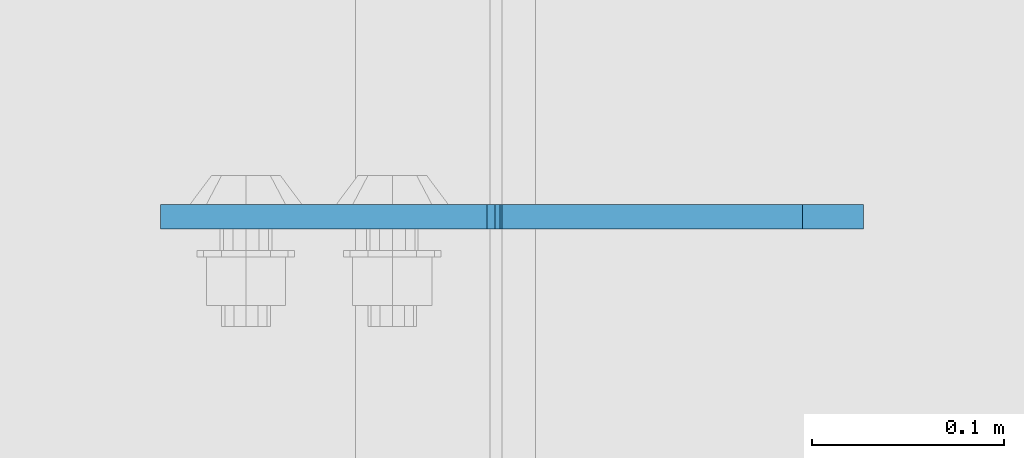
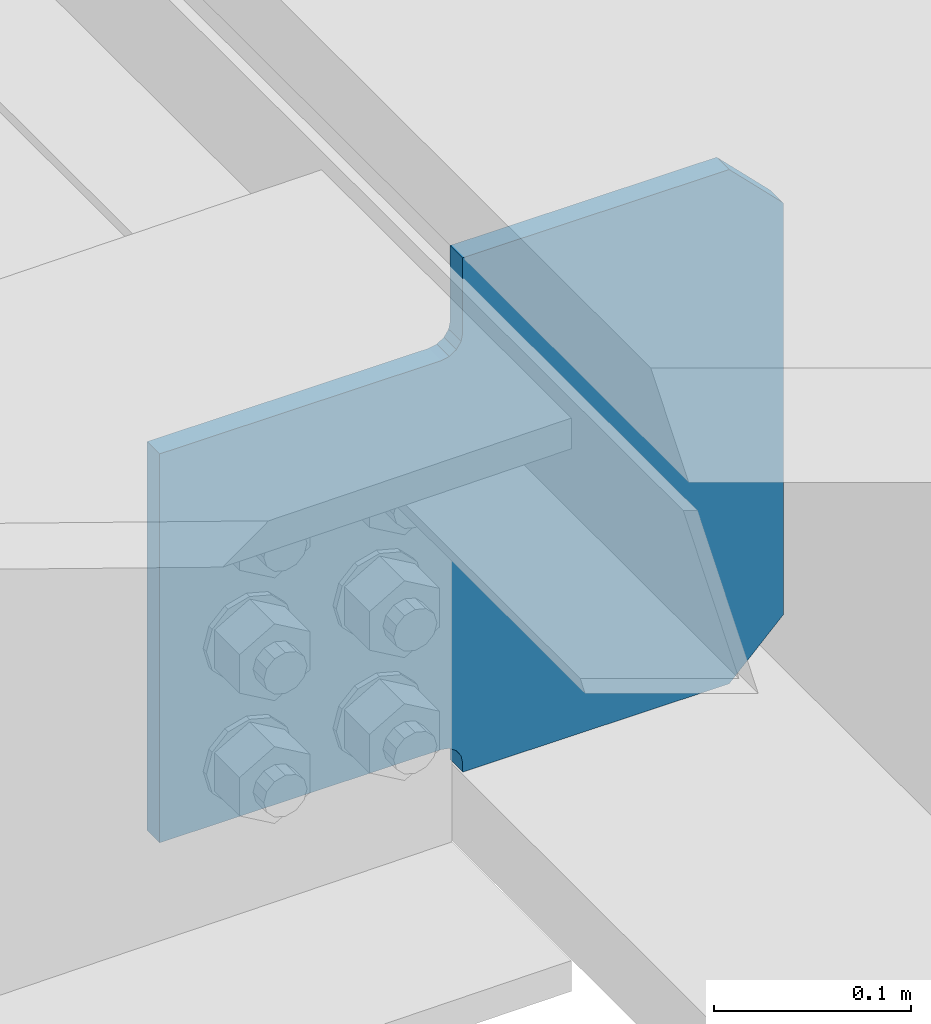
# One storey, part 3604 of 3843: 1 plate, 1 element without a shape of its own.
"""IFC2X3 building model written with IfcOpenShell, lengths in millimetres."""

from ifc_helpers import new_model, si_unit, frame, origin_with_axes, place, context, subcontext, project, spatial, faceted_brep, material, type_object, element, aggregate, save


model = new_model("IFC2X3")

# Units and contexts
model_context = context("Model", 3, precision=1e-05, world=origin_with_axes())
body_context = subcontext(model_context, "Body", "Model", "MODEL_VIEW")
ifc_project = project(units=[si_unit("LENGTHUNIT", "METRE", prefix="MILLI"), si_unit("AREAUNIT", "SQUARE_METRE"), si_unit("VOLUMEUNIT", "CUBIC_METRE"), si_unit("MASSUNIT", "GRAM", prefix="KILO"), si_unit("TIMEUNIT", "SECOND"), si_unit("PLANEANGLEUNIT", "RADIAN"), si_unit("SOLIDANGLEUNIT", "STERADIAN"), si_unit("THERMODYNAMICTEMPERATUREUNIT", "DEGREE_CELSIUS"), si_unit("LUMINOUSINTENSITYUNIT", "LUMEN")], contexts=[model_context])

# Site, building, storey
site_placement = place(None, origin_with_axes())
site = spatial("IfcSite", under=ifc_project, at=site_placement, CompositionType="ELEMENT")
building_placement = place(site_placement, origin_with_axes())
building = spatial("IfcBuilding", under=site, at=building_placement, Name="Undefined", CompositionType="ELEMENT")
storey_placement = place(building_placement, origin_with_axes())
storey = spatial("IfcBuildingStorey", under=building, at=storey_placement, Name="Undefined", CompositionType="ELEMENT", Elevation=0.0)

# Assembly, plate
assembly_placement = place(storey_placement, origin_with_axes())
assembly = element("IfcElementAssembly", 1, at=assembly_placement, inside=storey, Name="BEAM", AssemblyPlace="NOTDEFINED", PredefinedType="RIGID_FRAME")
ifc_material = material(Name="STEEL/A572-50")
plate_type = type_object("IfcPlateType", PredefinedType="NOTDEFINED")
plate_placement = place(assembly_placement, frame((85633.7187499934, 56141.1437540911, 39424.8772231567), z_axis=(-0.707106781186548, 0.0, 0.707106781186548), x_axis=(-0.707106781186548, 0.0, -0.707106781186548)))
plate = element("IfcPlate", 2, at=plate_placement, type_object=plate_type, material=ifc_material, Name="PLATE", context=body_context, shape_type="Brep", body=[
    faceted_brep([(0.0, -6.3499999046162, 0.0), (-180.723515413658, -6.34999999999854, 180.723515413709), (-180.723515413658, 6.34999999999854, 180.723515413709), (7.27595761418343e-12, 6.3499999046162, 0.0), (-180.723515413192, -6.34999999999854, 225.6247960193), (-180.723515413192, 6.34999999999854, 225.6247960193), (-70.1541119392932, -6.34999999999854, 336.194199493159), (-70.1541119392932, 6.34999999999854, 336.194199493159), (-37.1200418601948, -6.34999999999854, 303.160129636955), (-37.1200418601948, 6.34999999999854, 303.160129636955), (-32.9998653920484, -6.34999999999854, 300.407115736507), (-32.9998653920484, 6.34999999999854, 300.407115736507), (-28.1397858740092, -6.34999999999854, 299.440385813938), (-28.1397858740092, 6.34999999999854, 299.440385813938), (-23.2797063559556, -6.34999999999854, 300.407115736547), (-23.2797063559556, 6.34999999999854, 300.407115736547), (-19.1595298877801, -6.34999999999854, 303.160129637028), (-19.1595298877801, 6.34999999999854, 303.160129637028), (97.583799727654, -6.34999999999854, 419.903459251484), (97.583799727654, 6.34999999999854, 419.903459251484), (268.208666028193, -6.34999999999854, 249.278592951268), (268.208666028193, 6.34999999999854, 249.278592951268), (151.465336412817, -6.34999999999854, 132.535263336889), (151.465336412817, 6.34999999999854, 132.535263336889), (148.712322512278, -6.34999999999854, 128.415086868714), (148.712322512278, 6.34999999999854, 128.415086868714), (147.74559258965, -6.34999999999854, 123.555007350631), (147.74559258965, 6.34999999999854, 123.555007350631), (148.71232251222, -6.34999999999854, 118.694927832566), (148.71232251222, 6.34999999999854, 118.694927832566), (151.465336412701, -6.34999999999854, 114.574751364398), (151.465336412701, 6.34999999999854, 114.574751364398), (155.470684068496, -6.35000000000582, 110.569403464237), (155.470684068496, 6.35000000000582, 110.569403464237), (44.9012806051323, -6.35000000000582, -1.45519152283669e-11), (44.9012806051323, 6.35000000000582, -1.45519152283669e-11)], [[[0, 1, 2, 3]], [[1, 4, 5, 2]], [[4, 6, 7, 5]], [[6, 8, 9, 7]], [[8, 10, 11, 9]], [[10, 12, 13, 11]], [[12, 14, 15, 13]], [[14, 16, 17, 15]], [[16, 18, 19, 17]], [[18, 20, 21, 19]], [[20, 22, 23, 21]], [[22, 24, 25, 23]], [[24, 26, 27, 25]], [[26, 28, 29, 27]], [[28, 30, 31, 29]], [[30, 32, 33, 31]], [[32, 34, 35, 33]], [[34, 0, 3, 35]], [[5, 7, 9, 11, 13, 15, 17, 19, 21, 23, 25, 27, 29, 31, 33, 35, 3, 2]], [[34, 32, 30, 28, 26, 24, 22, 20, 18, 16, 14, 12, 10, 8, 6, 4, 1, 0]]]),
])
aggregate(assembly, [plate])

save(model, "model.ifc")
